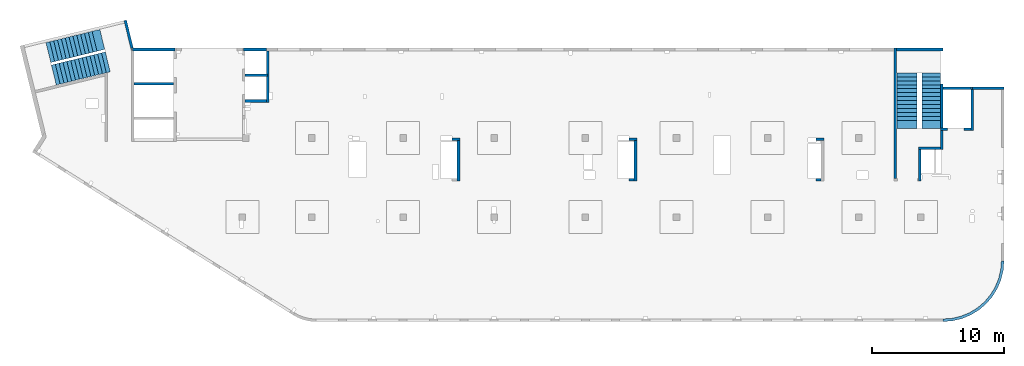
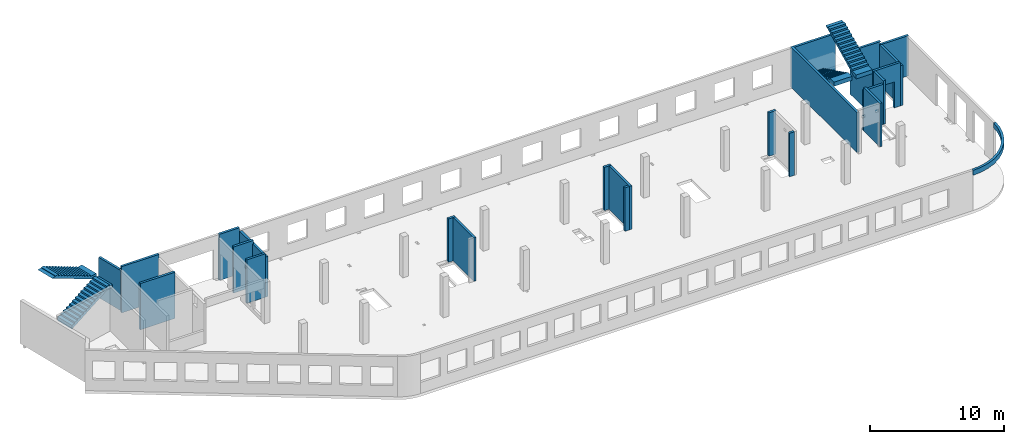
# One storey, part 3 of 7: 25 walls, 4 stairs, 1 opening.
"""IFC4 building model written with IfcOpenShell, lengths in millimetres."""

from ifc_helpers import new_model, entity, si_unit, converted_unit, derived_unit, direction, frame, origin, place, context, subcontext, project, spatial, indexed_curve, outline, extrude, polygons, material, type_object, element, save


model = new_model("IFC4")

# Units and contexts
model_context = context("Model", 3, precision=0.01, world=origin(), true_north=direction((6.12303176911189e-17, 1.0)))
plan_context = context("Plan", 3, precision=0.01, world=origin(), true_north=direction((6.12303176911189e-17, 1.0)))
body_context = subcontext(model_context, "Body", "Model", "MODEL_VIEW")
ifc_project = project(units=[si_unit("LENGTHUNIT", "METRE", prefix="MILLI"), si_unit("AREAUNIT", "SQUARE_METRE"), si_unit("VOLUMEUNIT", "CUBIC_METRE"), converted_unit("PLANEANGLEUNIT", "DEGREE", entity("IfcRatioMeasure", 0.0174532925199433), si_unit("PLANEANGLEUNIT", "RADIAN"), dimensions=[0, 0, 0, 0, 0, 0, 0]), si_unit("MASSUNIT", "GRAM", prefix="KILO"), derived_unit("MASSDENSITYUNIT", [(si_unit("MASSUNIT", "GRAM", prefix="KILO"), 1), (si_unit("LENGTHUNIT", "METRE"), -3)]), derived_unit("MOMENTOFINERTIAUNIT", [(si_unit("LENGTHUNIT", "METRE"), 4)]), si_unit("TIMEUNIT", "SECOND"), si_unit("FREQUENCYUNIT", "HERTZ"), si_unit("THERMODYNAMICTEMPERATUREUNIT", "DEGREE_CELSIUS"), derived_unit("THERMALTRANSMITTANCEUNIT", [(si_unit("MASSUNIT", "GRAM", prefix="KILO"), 1), (si_unit("THERMODYNAMICTEMPERATUREUNIT", "KELVIN"), -1), (si_unit("TIMEUNIT", "SECOND"), -3)]), derived_unit("VOLUMETRICFLOWRATEUNIT", [(si_unit("LENGTHUNIT", "METRE"), 3), (si_unit("TIMEUNIT", "SECOND"), -1)]), derived_unit("MASSFLOWRATEUNIT", [(si_unit("MASSUNIT", "GRAM", prefix="KILO"), 1), (si_unit("TIMEUNIT", "SECOND"), -1)]), derived_unit("ROTATIONALFREQUENCYUNIT", [(si_unit("TIMEUNIT", "SECOND"), -1)]), si_unit("ELECTRICCURRENTUNIT", "AMPERE"), si_unit("ELECTRICVOLTAGEUNIT", "VOLT"), si_unit("POWERUNIT", "WATT"), si_unit("FORCEUNIT", "NEWTON", prefix="KILO"), si_unit("ILLUMINANCEUNIT", "LUX"), si_unit("LUMINOUSFLUXUNIT", "LUMEN"), si_unit("LUMINOUSINTENSITYUNIT", "CANDELA"), derived_unit("USERDEFINED", [(si_unit("MASSUNIT", "GRAM", prefix="KILO"), -1), (si_unit("LENGTHUNIT", "METRE"), -2), (si_unit("TIMEUNIT", "SECOND"), 3), (si_unit("LUMINOUSFLUXUNIT", "LUMEN"), 1)]), derived_unit("LINEARVELOCITYUNIT", [(si_unit("LENGTHUNIT", "METRE"), 1), (si_unit("TIMEUNIT", "SECOND"), -1)]), si_unit("PRESSUREUNIT", "PASCAL"), derived_unit("USERDEFINED", [(si_unit("LENGTHUNIT", "METRE"), -2), (si_unit("MASSUNIT", "GRAM", prefix="KILO"), 1), (si_unit("TIMEUNIT", "SECOND"), -2)]), derived_unit("LINEARFORCEUNIT", [(si_unit("MASSUNIT", "GRAM", prefix="KILO"), 1), (si_unit("LENGTHUNIT", "METRE"), 1), (si_unit("TIMEUNIT", "SECOND"), -2), (si_unit("LENGTHUNIT", "METRE"), -1)]), derived_unit("PLANARFORCEUNIT", [(si_unit("MASSUNIT", "GRAM", prefix="KILO"), 1), (si_unit("LENGTHUNIT", "METRE"), 1), (si_unit("TIMEUNIT", "SECOND"), -2), (si_unit("LENGTHUNIT", "METRE"), -2)])], contexts=[model_context, plan_context])

# Site, building, storey
site_placement = place(None, origin())
site = spatial("IfcSite", under=ifc_project, at=site_placement, CompositionType="ELEMENT")
building_placement = place(site_placement, origin())
building = spatial("IfcBuilding", under=site, at=building_placement, CompositionType="ELEMENT")
storey_placement = place(building_placement, frame((0.0, 0.0, 12000.0)))
storey = spatial("IfcBuildingStorey", under=building, at=storey_placement, CompositionType="ELEMENT", Elevation=12000.0)

# Walls
ifc_material_1 = material()
wall_type = type_object("IfcWallType", PredefinedType="STANDARD")
wall_1_placement = place(storey_placement, frame((71069.9994506836, 17469.9992263555, -150.0)))
element("IfcWall", 1, at=wall_1_placement, inside=storey, type_object=wall_type, material=ifc_material_1, PredefinedType="NOTDEFINED", context=body_context, shape_type="SweptSolid", body=[
    extrude(outline(indexed_curve([(2500.00000000001, -99.9999999999999), (2500.00000000001, 100.0), (99.9999999999943, 99.9999999999992), (99.9999999999949, -100.000000000001), (199.999999999998, -100.0), (2300.00000000001, -100.0), (2500.00000000001, -99.9999999999999)], self_intersect=False)), origin(), (0.0, 0.0, 1.0), 3650.0),
])
wall_2_placement = place(storey_placement, frame((71169.9994506836, 17369.9992263555, -150.0), z_axis=(0.0, 0.0, 1.0), x_axis=(0.0, -1.0, 0.0)))
element("IfcWall", 2, at=wall_2_placement, inside=storey, type_object=wall_type, material=ifc_material_1, PredefinedType="NOTDEFINED", context=body_context, shape_type="SweptSolid", body=[
    extrude(outline(indexed_curve([(3100.0, 100.000000000003), (-2.79449581754433e-13, 100.000000000003), (2.79449581754433e-13, -100.000000000003), (3100.0, -100.000000000003), (3100.0, 100.000000000003)], self_intersect=False)), origin(), (0.0, 0.0, 1.0), 3650.0),
])

# Wall, opening
wall_3_placement = place(storey_placement, frame((71069.9994506836, 14369.9992263555, -150.0), z_axis=(0.0, 0.0, 1.0), x_axis=(-1.0, 0.0, 0.0)))
wall_3 = element("IfcWall", 3, at=wall_3_placement, inside=storey, type_object=wall_type, material=ifc_material_1, PredefinedType="NOTDEFINED", context=body_context, shape_type="Tessellation", body=[
    polygons([(2299.99918212887, -100.000000000003, 3950.0), (2099.99918212887, -100.000000000001, 3950.0), (-2.4387927500343e-12, -100.000000000001, 3950.0), (-2.4387927500343e-12, -100.000000000001, 0.0), (529.999182128873, -100.000000000001, 0.0), (529.999182128864, -100.000000000001, 2369.99999999804), (1769.99918212887, -99.9999999999989, 2369.99999999804), (1769.99918212887, -100.000000000003, 0.0), (2099.99918212886, -100.000000000003, 0.0), (2099.99918212886, -100.000000000003, 49.9999999999973), (2299.99918212887, -100.000000000003, 49.9999999999973), (2299.99918212887, -100.000000000001, 3650.0), (-3.00376710535355e-12, 99.9999999999968, 3950.0), (2099.99918212887, 99.9999999999989, 3950.0), (2299.99918212887, 99.9999999999989, 3950.0), (2299.99918212887, 99.9999999999989, 3900.0), (2299.99918212887, 99.9999999999989, 49.9999999999973), (2099.99918212886, 99.9999999999989, 49.9999999999973), (2099.99918212886, 99.9999999999989, 0.0), (1769.99918212887, 99.9999999999989, 0.0), (1769.99918212887, 99.9999999999989, 2369.99999999804), (529.999182128872, 99.9999999999989, 2369.99999999804), (529.999182128872, 99.9999999999989, 0.0), (-3.00376710535355e-12, 99.9999999999968, 0.0), (-3.00376710535355e-12, 99.9999999999989, 3650.0)], [[[1, 2, 3, 4, 5, 6, 7, 8, 9, 10, 11, 12]], [[13, 14, 15, 16, 17, 18, 19, 20, 21, 22, 23, 24, 25]], [[4, 24, 23, 5]], [[3, 2, 1, 15, 14, 13]], [[4, 3, 13, 25, 24]], [[6, 22, 21, 7]], [[7, 21, 20, 8]], [[22, 6, 5, 23]], [[11, 10, 18, 17]], [[10, 9, 19, 18]], [[11, 17, 16, 15, 1, 12]], [[19, 9, 8, 20]]], closed=True),
])
opening_placement = place(wall_3_placement, frame((71069.9994506836, 14369.9992263555, 150.0), z_axis=(0.0, 0.0, 1.0), x_axis=(-1.0, 0.0, 0.0)))
element("IfcOpeningElement", 4, at=opening_placement, cuts=wall_3, PredefinedType="OPENING", context=body_context, shape_type="SweptSolid", body=[
    extrude(outline(indexed_curve([(-619.999999999998, -1184.99999999902), (620.000000000006, -1184.99999999902), (620.000000000006, 1184.99999999902), (-619.999999999998, 1184.99999999902), (-619.999999999998, -1184.99999999902)], self_intersect=False)), frame((69920.0002685547, 14569.9992263574, 1035.0), z_axis=(0.0, -1.0, 0.0), x_axis=(-1.0, 0.0, 0.0)), (0.0, 0.0, 1.0), 400.000000001943),
])

# Walls
wall_4_placement = place(storey_placement, frame((68870.0002685547, 14269.9992263555, -150.0), z_axis=(0.0, 0.0, 1.0), x_axis=(0.0, -1.0, 0.0)))
element("IfcWall", 5, at=wall_4_placement, inside=storey, type_object=wall_type, material=ifc_material_1, PredefinedType="NOTDEFINED", context=body_context, shape_type="SweptSolid", body=[
    extrude(outline(indexed_curve([(1439.99999999999, 100.000000000003), (0.0, 100.000000000003), (0.0, -100.000000000003), (1439.99999999999, -100.000000000003), (1439.99999999999, 100.000000000003)], self_intersect=False)), origin(), (0.0, 0.0, 1.0), 3950.0),
])
wall_5_placement = place(storey_placement, frame((68770.0002685547, 12929.9992263555, -150.0), z_axis=(0.0, 0.0, 1.0), x_axis=(-1.0, 0.0, 0.0)))
element("IfcWall", 6, at=wall_5_placement, inside=storey, type_object=wall_type, material=ifc_material_1, PredefinedType="NOTDEFINED", context=body_context, shape_type="SweptSolid", body=[
    extrude(outline(indexed_curve([(1689.99999999997, 99.9999999999989), (-3.84449868389964e-13, 99.9999999999989), (3.84449868389964e-13, -99.9999999999989), (1689.99999999997, -99.9999999999989), (1689.99999999997, 99.9999999999989)], self_intersect=False)), origin(), (0.0, 0.0, 1.0), 3650.0),
])
wall_6_placement = place(storey_placement, frame((67180.0002685547, 12829.9992263555, -150.0), z_axis=(0.0, 0.0, 1.0), x_axis=(0.0, -1.0, 0.0)))
element("IfcWall", 7, at=wall_6_placement, inside=storey, type_object=wall_type, material=ifc_material_1, PredefinedType="NOTDEFINED", context=body_context, shape_type="SweptSolid", body=[
    extrude(outline(indexed_curve([(2404.99999999995, 100.000000000003), (0.0, 100.000000000003), (0.0, -100.000000000003), (2404.99999999995, -100.000000000003), (2404.99999999995, 100.000000000003)], self_intersect=False)), origin(), (0.0, 0.0, 1.0), 3950.0),
])
wall_7_placement = place(storey_placement, frame((65330.0002685547, 10624.9992263555, -150.0), z_axis=(0.0, 0.0, 1.0), x_axis=(0.0, 1.0, 0.0)))
element("IfcWall", 8, at=wall_7_placement, inside=storey, type_object=wall_type, material=ifc_material_1, PredefinedType="NOTDEFINED", context=body_context, shape_type="SweptSolid", body=[
    extrude(outline(indexed_curve([(9875.00063936713, 100.000000000003), (-1.71685740578866e-13, 100.000000000003), (1.71685740578866e-13, -100.000000000003), (9875.00063936713, -100.000000000004), (9875.00063936713, 100.000000000003)], self_intersect=False)), origin(), (0.0, 0.0, 1.0), 3650.0),
])
wall_8_placement = place(storey_placement, frame((68970.0002685545, -99.9999557734324, 3050.0)))
element("IfcWall", 9, at=wall_8_placement, inside=storey, type_object=wall_type, material=ifc_material_1, PredefinedType="NOTDEFINED", context=body_context, shape_type="SweptSolid", body=[
    extrude(outline(indexed_curve([(4399.99918212903, 4499.99918212888), (4345.82789081698, 3811.68766389508), (4184.64789385715, 3140.32465961517), (3920.42797770043, 2502.44135458057), (3559.67411357824, 1913.74455277455), (3111.26925889869, 1388.72992323025), (2586.25462935438, 940.325068550716), (1997.55782754836, 579.571204428538), (1359.67452251375, 315.351288271842), (688.311518233829, 154.171291312031), (3.46517481375486e-11, 100.0), (0.0, -100.0), (719.598411241839, -43.3663768070014), (1421.47792138871, 125.139985012801), (2088.35592749623, 401.369899590849), (2703.81167981284, 778.521669675706), (3252.69061513597, 1247.30856699292), (3721.47751245321, 1796.18750231603), (4098.6292825381, 2411.64325463263), (4374.85919711618, 3078.52126074015), (4543.365558936, 3780.40077088701), (4599.99918212903, 4499.99918212885), (4399.99918212903, 4499.99918212888)], self_intersect=False)), origin(), (0.0, 0.0, 1.0), 450.000000000002),
])
wall_9_placement = place(storey_placement, frame((17825.0002685547, 20299.9998657227, -150.0), z_axis=(0.0, 0.0, 1.0), x_axis=(0.0, -1.0, 0.0)))
element("IfcWall", 10, at=wall_9_placement, inside=storey, type_object=wall_type, material=ifc_material_1, PredefinedType="NOTDEFINED", context=body_context, shape_type="SweptSolid", body=[
    extrude(outline(indexed_curve([(3900.00063936684, 99.9999999999989), (-1.66594915657375e-13, 99.9999999999989), (1.66594915657375e-13, -99.9999999999989), (3900.00063936684, -99.9999999999989), (3900.00063936684, 99.9999999999989)], self_intersect=False)), origin(), (0.0, 0.0, 1.0), 3650.0),
])
wall_10_placement = place(storey_placement, frame((17725.0002685547, 16499.9992263558, -150.0), z_axis=(0.0, 0.0, 1.0), x_axis=(-1.0, 0.0, 0.0)))
element("IfcWall", 11, at=wall_10_placement, inside=storey, type_object=wall_type, material=ifc_material_1, PredefinedType="NOTDEFINED", context=body_context, shape_type="SweptSolid", body=[
    extrude(outline(indexed_curve([(1624.99999999999, 99.9999999999982), (-3.56011111002209e-13, 99.9999999999989), (3.56011111002209e-13, -99.9999999999989), (1624.99999999999, -99.9999999999996), (1624.99999999999, 99.9999999999982)], self_intersect=False)), origin(), (0.0, 0.0, 1.0), 3950.0),
])
wall_11_placement = place(storey_placement, frame((68870.0002685547, 17779.9992263555, -400.0), z_axis=(0.0, 0.0, 1.0), x_axis=(0.0, -1.0, 0.0)))
element("IfcWall", 12, at=wall_11_placement, inside=storey, type_object=wall_type, material=ifc_material_1, PredefinedType="NOTDEFINED", context=body_context, shape_type="Tessellation", body=[
    polygons([(2.16573425859679e-12, -99.9999999999946, 0.0), (3310.0, -99.9999999999946, 0.0), (3310.0, -99.9999999999946, 299.999999999997), (3310.0, -99.9999999999946, 3900.0), (2.16573425859679e-12, -99.9999999999946, 3900.0), (3310.0, 100.000000000012, 0.0), (410.0, 100.000000000003, 0.0), (210.0, 100.000000000003, 0.0), (2.16573425859679e-12, 100.000000000012, 0.0), (2.16573425859679e-12, 100.000000000012, 3900.0), (3310.0, 100.000000000012, 3900.0)], [[[1, 2, 3, 4, 5]], [[6, 7, 8, 9, 10, 11]], [[2, 1, 9, 8, 7, 6]], [[9, 1, 5, 10]], [[2, 6, 11, 4, 3]], [[5, 4, 11, 10]]], closed=True),
])
wall_12_placement = place(storey_placement, frame((68970.0002685547, 17469.9992263555, -400.0)))
element("IfcWall", 13, at=wall_12_placement, inside=storey, type_object=wall_type, material=ifc_material_1, PredefinedType="NOTDEFINED", context=body_context, shape_type="Tessellation", body=[
    polygons([(2199.99918212887, -100.000000000001, 4200.0), (2099.99918212888, -100.000000000001, 4200.0), (6.89939203009021e-12, -100.000000000001, 4200.0), (6.89939203009021e-12, -100.000000000001, 0.0), (2099.99918212889, -100.000000000001, 0.0), (2099.99918212889, -100.000000000001, 249.999999999999), (2199.99918212887, -100.000000000001, 249.999999999999), (2199.99918212887, -100.000000000001, 299.999999999997), (2099.99918212888, -100.000000000001, 299.999999999997), (2099.99918212889, -100.000000000001, 3900.0), (2099.99918212889, -100.000000000001, 4150.0), (2199.99918212887, -100.000000000001, 4150.0), (6.28061057235613e-12, 99.9999999999989, 4200.0), (2099.99918212888, 99.9999999999989, 4200.0), (2199.99918212887, 99.9999999999989, 4200.0), (2199.99918212887, 99.9999999999989, 4150.0), (2099.99918212889, 99.9999999999946, 4150.0), (2099.99918212889, 99.9999999999989, 3900.0), (2099.99918212888, 99.9999999999989, 299.999999999997), (2199.99918212887, 99.9999999999989, 299.999999999997), (2199.99918212887, 99.9999999999989, 249.999999999999), (2099.99918212889, 99.9999999999946, 249.999999999999), (2099.99918212889, 99.9999999999989, 0.0), (6.28061057235613e-12, 99.9999999999989, 0.0)], [[[1, 2, 3, 4, 5, 6, 7, 8, 9, 10, 11, 12]], [[13, 14, 15, 16, 17, 18, 19, 20, 21, 22, 23, 24]], [[4, 24, 23, 5]], [[3, 2, 1, 15, 14, 13]], [[20, 8, 7, 21]], [[9, 19, 18, 17, 11, 10]], [[15, 1, 12, 16]], [[3, 13, 24, 4]], [[9, 8, 20, 19]], [[6, 22, 21, 7]], [[22, 6, 5, 23]], [[11, 17, 16, 12]]], closed=True),
])
wall_13_placement = place(storey_placement, frame((65430.0002685547, 20399.9998657227, -400.0)))
element("IfcWall", 14, at=wall_13_placement, inside=storey, type_object=wall_type, material=ifc_material_1, PredefinedType="NOTDEFINED", context=body_context, shape_type="SweptSolid", body=[
    extrude(outline(indexed_curve([(3539.99999999995, 99.9999999999989), (-3.67073603151997e-13, 99.9999999999989), (3.67073603151997e-13, -99.9999999999989), (3539.99999999995, -99.9999999999989), (3539.99999999995, 99.9999999999989)], self_intersect=False)), origin(), (0.0, 0.0, 1.0), 3900.0),
])
wall_14_placement = place(storey_placement, frame((16000.0002685547, 20399.9998657227, -400.0)))
element("IfcWall", 15, at=wall_14_placement, inside=storey, type_object=wall_type, material=ifc_material_1, PredefinedType="NOTDEFINED", context=body_context, shape_type="SweptSolid", body=[
    extrude(outline(indexed_curve([(1724.99999999999, -100.000000000003), (1724.99999999999, 99.9999999999992), (99.9999999999987, 99.9999999999992), (-2.66551908750372e-13, 99.9999999999989), (2.66551908750383e-13, -100.000000000003), (99.9999999999992, -100.000000000003), (1724.99999999999, -100.000000000003)], self_intersect=False)), origin(), (0.0, 0.0, 1.0), 4200.0),
])
wall_15_placement = place(storey_placement, frame((16100.0002685547, 18449.9998657227, -400.0)))
element("IfcWall", 16, at=wall_15_placement, inside=storey, type_object=wall_type, material=ifc_material_1, PredefinedType="NOTDEFINED", context=body_context, shape_type="SweptSolid", body=[
    extrude(outline(indexed_curve([(1725.0, 99.9999999999992), (-2.66551908750371e-13, 99.9999999999989), (2.66551908750371e-13, -99.9999999999989), (1725.0, -99.9999999999987), (1725.0, 99.9999999999992)], self_intersect=False)), origin(), (0.0, 0.0, 1.0), 4200.0),
])
wall_16_placement = place(storey_placement, frame((7500.0002685547, 20399.9998657227, -400.0)))
element("IfcWall", 17, at=wall_16_placement, inside=storey, type_object=wall_type, material=ifc_material_1, PredefinedType="NOTDEFINED", context=body_context, shape_type="SweptSolid", body=[
    extrude(outline(indexed_curve([(3300.0, -100.000000000002), (3300.0, 99.9999999999998), (3200.0, 99.9999999999995), (99.9999999999997, 99.9999999999992), (99.9999999999992, -100.000000000003), (3300.0, -100.000000000002)], self_intersect=False)), origin(), (0.0, 0.0, 1.0), 4200.0),
])
wall_17_placement = place(storey_placement, frame((7700.0002685547, 17799.9998657227, -400.0)))
element("IfcWall", 18, at=wall_17_placement, inside=storey, type_object=wall_type, material=ifc_material_1, PredefinedType="NOTDEFINED", context=body_context, shape_type="SweptSolid", body=[
    extrude(outline(indexed_curve([(3000.0, 99.9999999999989), (-2.88764567812902e-13, 99.9999999999989), (2.88764567812902e-13, -99.9999999999989), (3000.0, -99.9999999999989), (3000.0, 99.9999999999989)], self_intersect=False)), origin(), (0.0, 0.0, 1.0), 4200.0),
])
wall_18_placement = place(storey_placement, frame((59330.0002685547, 13599.9992263555, -150.0)))
element("IfcWall", 19, at=wall_18_placement, inside=storey, type_object=wall_type, material=ifc_material_1, PredefinedType="NOTDEFINED", context=body_context, shape_type="SweptSolid", body=[
    extrude(outline(indexed_curve([(599.999999999993, 99.9999999999989), (-3.60955709766131e-13, 99.9999999999989), (3.60955709766131e-13, -99.9999999999989), (599.999999999994, -99.9999999999989), (599.999999999993, 99.9999999999989)], self_intersect=False)), origin(), (0.0, 0.0, 1.0), 3950.0),
])
wall_19_placement = place(storey_placement, frame((59730.0002685547, 10524.9992263555, -150.0), z_axis=(0.0, 0.0, 1.0), x_axis=(-1.0, 0.0, 0.0)))
element("IfcWall", 20, at=wall_19_placement, inside=storey, type_object=wall_type, material=ifc_material_1, PredefinedType="NOTDEFINED", context=body_context, shape_type="SweptSolid", body=[
    extrude(outline(indexed_curve([(399.999999999987, 99.9999999999982), (-3.60955709766136e-13, 99.9999999999989), (3.60955709766136e-13, -99.9999999999989), (399.999999999987, -99.9999999999996), (399.999999999987, 99.9999999999982)], self_intersect=False)), origin(), (0.0, 0.0, 1.0), 3950.0),
])
wall_20_placement = place(storey_placement, frame((45170.0002685547, 13599.9992263556, -150.0)))
element("IfcWall", 21, at=wall_20_placement, inside=storey, type_object=wall_type, material=ifc_material_1, PredefinedType="NOTDEFINED", context=body_context, shape_type="SweptSolid", body=[
    extrude(outline(indexed_curve([(599.999999999993, 99.9999999999989), (-3.60955709766131e-13, 99.9999999999989), (3.60955709766131e-13, -99.9999999999989), (599.999999999994, -99.9999999999989), (599.999999999993, 99.9999999999989)], self_intersect=False)), origin(), (0.0, 0.0, 1.0), 3950.0),
])
wall_21_placement = place(storey_placement, frame((45670.0002685547, 13499.9992263556, -150.0), z_axis=(0.0, 0.0, 1.0), x_axis=(0.0, -1.0, 0.0)))
element("IfcWall", 22, at=wall_21_placement, inside=storey, type_object=wall_type, material=ifc_material_1, PredefinedType="NOTDEFINED", context=body_context, shape_type="SweptSolid", body=[
    extrude(outline(indexed_curve([(3074.99985044015, 100.000000000003), (-2.64517173435081e-13, 100.000000000003), (2.64517173435081e-13, -100.000000000003), (3074.99985044015, -100.000000000004), (3074.99985044015, 100.000000000003)], self_intersect=False)), origin(), (0.0, 0.0, 1.0), 3950.0),
])
wall_22_placement = place(storey_placement, frame((45570.0002685547, 10524.9993759154, -150.0), z_axis=(0.0, 0.0, 1.0), x_axis=(-1.0, 0.0, 0.0)))
element("IfcWall", 23, at=wall_22_placement, inside=storey, type_object=wall_type, material=ifc_material_1, PredefinedType="NOTDEFINED", context=body_context, shape_type="SweptSolid", body=[
    extrude(outline(indexed_curve([(399.999999999995, 99.9999999999982), (-3.60955709766131e-13, 99.9999999999989), (3.60955709766131e-13, -99.9999999999989), (399.999999999996, -99.9999999999996), (399.999999999995, 99.9999999999982)], self_intersect=False)), origin(), (0.0, 0.0, 1.0), 3950.0),
])
wall_23_placement = place(storey_placement, frame((31770.0002685547, 13599.9992263557, -150.0)))
element("IfcWall", 24, at=wall_23_placement, inside=storey, type_object=wall_type, material=ifc_material_1, PredefinedType="NOTDEFINED", context=body_context, shape_type="SweptSolid", body=[
    extrude(outline(indexed_curve([(600.000000000002, 99.9999999999989), (-3.60955709766126e-13, 99.9999999999989), (3.60955709766126e-13, -99.9999999999989), (600.000000000003, -99.9999999999989), (600.000000000002, 99.9999999999989)], self_intersect=False)), origin(), (0.0, 0.0, 1.0), 3950.0),
])
wall_24_placement = place(storey_placement, frame((32270.0002685547, 13499.9992263557, -150.0), z_axis=(0.0, 0.0, 1.0), x_axis=(0.0, -1.0, 0.0)))
element("IfcWall", 25, at=wall_24_placement, inside=storey, type_object=wall_type, material=ifc_material_1, PredefinedType="NOTDEFINED", context=body_context, shape_type="SweptSolid", body=[
    extrude(outline(indexed_curve([(3074.99985044025, 99.9999999999987), (-1.32258586717531e-13, 99.9999999999989), (1.32258586717531e-13, -99.9999999999989), (3074.99985044025, -99.9999999999992), (3074.99985044025, 99.9999999999987)], self_intersect=False)), origin(), (0.0, 0.0, 1.0), 3950.0),
])
wall_25_placement = place(storey_placement, frame((7033.44218130896, 22609.751914045, -150.0), z_axis=(0.0, 0.0, 1.0), x_axis=(0.236826092990328, -0.971552058141475, 0.0)))
element("IfcWall", 26, at=wall_25_placement, inside=storey, type_object=wall_type, material=ifc_material_1, PredefinedType="NOTDEFINED", context=body_context, shape_type="SweptSolid", body=[
    extrude(outline(indexed_curve([(2380.28371765147, -99.9999999999991), (2354.53748529952, -93.7240834744376), (2160.22707367122, -46.3588648763715), (2195.90359543113, 99.9999999999994), (-1.39588340886121e-13, 99.9999999999987), (-1.1420864254319e-13, -99.9999999999997), (199.999999999995, -100.0), (2380.28371765147, -99.9999999999991)], self_intersect=False)), origin(), (0.0, 0.0, 1.0), 3650.0),
])

# Stairs
ifc_material_2 = material()
stair_type_1 = type_object("IfcStairType", PredefinedType="HALF_TURN_STAIR")
stair_1_placement = place(storey_placement, origin())
element("IfcStair", 27, at=stair_1_placement, inside=storey, type_object=stair_type_1, material=ifc_material_2, PredefinedType="HALF_TURN_STAIR", context=body_context, shape_type="SweptSolid", body=[
    extrude(outline(indexed_curve([(843.870967741944, -2179.17507067742), (1213.87096774194, -2179.17507067742), (1213.87096774195, -1871.96147517747), (-906.129032258053, 2368.03852482254), (-906.129032258053, 2020.82492932259), (-956.129032258054, 2020.82492932259), (-956.129032258054, 1720.82492932259), (-806.129032258056, 1720.82492932259), (-806.129032258056, 1420.82492932259), (-656.129032258055, 1420.82492932259), (-656.129032258055, 1120.82492932259), (-506.129032258057, 1120.82492932259), (-506.129032258057, 820.824929322588), (-356.129032258056, 820.824929322588), (-356.129032258056, 520.824929322586), (-206.129032258056, 520.824929322586), (-206.129032258056, 220.824929322585), (-56.1290322580552, 220.824929322585), (-56.1290322580552, -79.1750706774158), (93.8709677419453, -79.1750706774158), (93.8709677419453, -379.175070677417), (243.870967741946, -379.175070677417), (243.870967741946, -679.175070677418), (393.870967741944, -679.175070677418), (393.870967741944, -979.175070677419), (543.870967741945, -979.175070677419), (543.870967741945, -1279.17507067742), (693.870967741945, -1279.17507067742), (693.870967741945, -1579.17507067742), (843.870967741944, -1579.17507067742), (843.870967741944, -2179.17507067742)], self_intersect=False)), frame((67360.0002685547, 16609.1742970334, 4713.87096774195), z_axis=(1.0, 0.0, 0.0), x_axis=(0.0, 0.0, -1.0)), (0.0, 0.0, 1.0), 1390.0),
])
stair_type_2 = type_object("IfcStairType", PredefinedType="HALF_TURN_STAIR")
stair_2_placement = place(storey_placement, origin())
element("IfcStair", 28, at=stair_2_placement, inside=storey, type_object=stair_type_2, material=ifc_material_2, PredefinedType="HALF_TURN_STAIR", context=body_context, shape_type="SweptSolid", body=[
    extrude(outline(indexed_curve([(-1961.8142397, -852.000000000003), (-1961.8142397, -1202.0), (-1914.60064420005, -1202.00000000001), (1645.39935579996, 577.999999999996), (2238.18576029999, 577.999999999996), (2238.18576029999, 947.999999999997), (1638.18576030001, 947.999999999997), (1638.18576030001, 797.999999999998), (1338.18576030001, 797.999999999998), (1338.18576030001, 647.999999999998), (1038.18576030001, 647.999999999998), (1038.18576030001, 497.999999999997), (738.185760300006, 497.999999999997), (738.185760300006, 347.999999999997), (438.185760300005, 347.999999999997), (438.185760300005, 197.999999999996), (138.185760300003, 197.999999999996), (138.185760300003, 47.9999999999977), (-161.814239699998, 47.9999999999977), (-161.814239699998, -102.000000000003), (-461.814239699999, -102.000000000003), (-461.814239699999, -252.000000000003), (-761.8142397, -252.000000000003), (-761.8142397, -402.000000000002), (-1061.8142397, -402.000000000002), (-1061.8142397, -552.000000000002), (-1361.8142397, -552.000000000002), (-1361.8142397, -702.000000000003), (-1661.8142397, -702.000000000003), (-1661.8142397, -852.000000000003), (-1961.8142397, -852.000000000003)], self_intersect=False)), frame((65450.0002685547, 16668.184986656, 2922.0), z_axis=(-1.0, 0.0, 0.0), x_axis=(0.0, -1.0, 0.0)), (0.0, 0.0, -1.0), 1550.0),
])
stair_type_3 = type_object("IfcStairType", PredefinedType="HALF_TURN_STAIR")
stair_3_placement = place(storey_placement, origin())
element("IfcStair", 29, at=stair_3_placement, inside=storey, type_object=stair_type_3, material=ifc_material_2, PredefinedType="HALF_TURN_STAIR", context=body_context, shape_type="SweptSolid", body=[
    extrude(outline(indexed_curve([(872.000000000003, -2240.93152968505), (1242.0, -2240.93152968505), (1242.0, -1934.66369491541), (-878.000000000008, 2305.33630508466), (-878.00000000001, 1958.12270958467), (-927.999999999994, 1958.12270958467), (-927.999999999993, 1658.12270958467), (-777.999999999993, 1658.12270958467), (-777.999999999994, 1358.12270958466), (-627.999999999993, 1358.12270958466), (-627.999999999992, 1058.12270958466), (-477.999999999994, 1058.12270958466), (-477.999999999993, 758.122709584654), (-327.999999999993, 758.122709584654), (-327.999999999994, 458.12270958465), (-177.999999999993, 458.12270958465), (-177.999999999995, 158.122709584646), (-27.9999999999941, 158.122709584645), (-27.9999999999954, -141.877290415355), (122.000000000005, -141.877290415355), (122.000000000006, -441.877290415358), (272.000000000004, -441.877290415359), (272.000000000005, -741.877290415362), (422.000000000006, -741.877290415362), (422.000000000004, -1041.87729041536), (572.000000000003, -1041.87729041537), (572.000000000004, -1341.87729041537), (722.000000000004, -1341.87729041537), (722.000000000003, -1641.87729041537), (872.000000000003, -1641.87729041537), (872.000000000003, -2240.93152968505)], self_intersect=False)), frame((3302.2808970065, 19878.4146408221, 4742.0), z_axis=(-0.236826092990341, 0.971552058141472, 0.0), x_axis=(0.0, 0.0, -1.0)), (0.0, 0.0, 1.0), 1550.00000000006),
])
stair_type_4 = type_object("IfcStairType", PredefinedType="HALF_TURN_STAIR")
stair_4_placement = place(storey_placement, origin())
element("IfcStair", 30, at=stair_4_placement, inside=storey, type_object=stair_type_4, material=ifc_material_2, PredefinedType="HALF_TURN_STAIR", context=body_context, shape_type="SweptSolid", body=[
    extrude(outline(indexed_curve([(-2082.95035407268, -903.75), (-2082.95035407268, -1253.75), (-2035.73675857273, -1253.75), (1524.26324142725, 526.249999999975), (2117.04171559009, 526.249999999973), (2117.0417155901, 776.249999999969), (1817.04964592736, 776.249999999971), (1817.04964592736, 896.250000000006), (1517.04964592735, 896.250000000006), (1517.04964592735, 746.250000000006), (1217.04964592735, 746.250000000006), (1217.04964592735, 596.250000000005), (917.049645927347, 596.250000000005), (917.049645927346, 446.250000000005), (617.049645927341, 446.250000000005), (617.049645927341, 296.250000000004), (317.049645927337, 296.250000000004), (317.049645927336, 146.250000000003), (17.0496459273321, 146.250000000003), (17.049645927331, -3.74999999999711), (-282.950354072671, -3.74999999999711), (-282.950354072672, -153.749999999998), (-582.950354072675, -153.749999999998), (-582.950354072676, -303.749999999998), (-882.950354072678, -303.749999999998), (-882.950354072679, -453.749999999999), (-1182.95035407268, -453.749999999999), (-1182.95035407268, -603.749999999999), (-1482.95035407268, -603.749999999999), (-1482.95035407268, -753.75), (-1782.95035407268, -753.75), (-1782.95035407268, -903.75), (-2082.95035407268, -903.75)], self_intersect=False)), frame((3838.00311465482, 18207.7609824159, 2973.75000000002), z_axis=(0.236826092990333, -0.971552058141474, 0.0), x_axis=(0.971552058141474, 0.236826092990333, 0.0)), (0.0, 0.0, -1.0), 1550.0),
])

save(model, "model.ifc")
